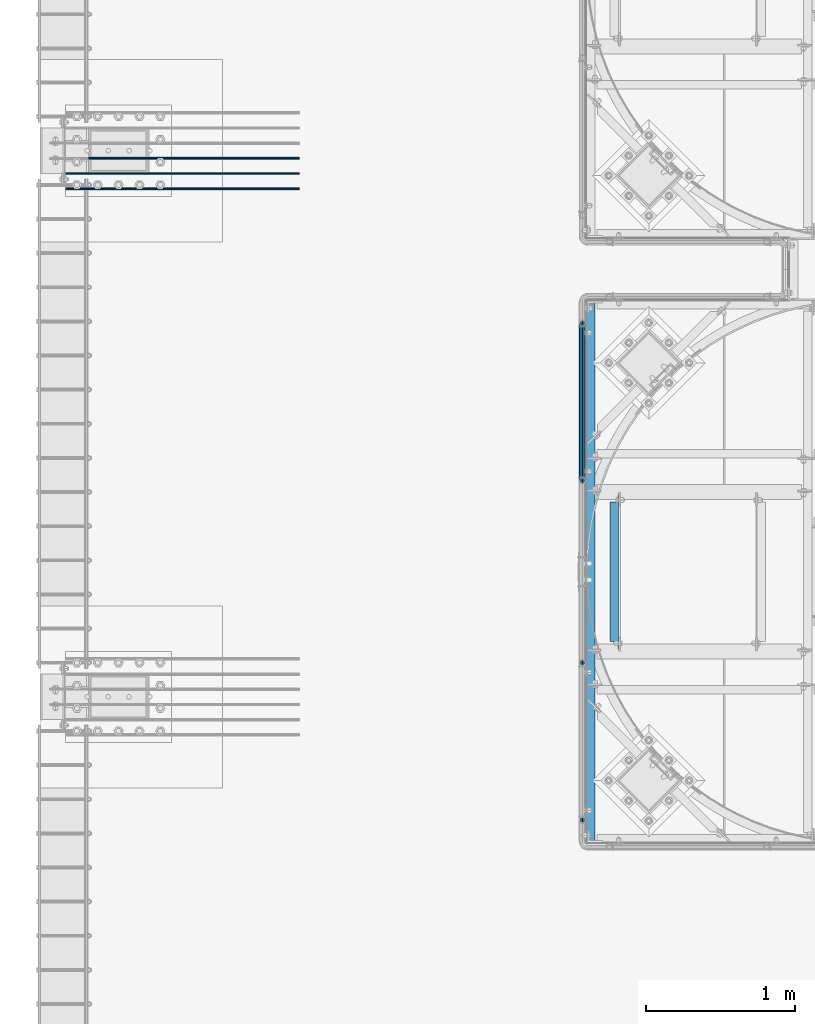
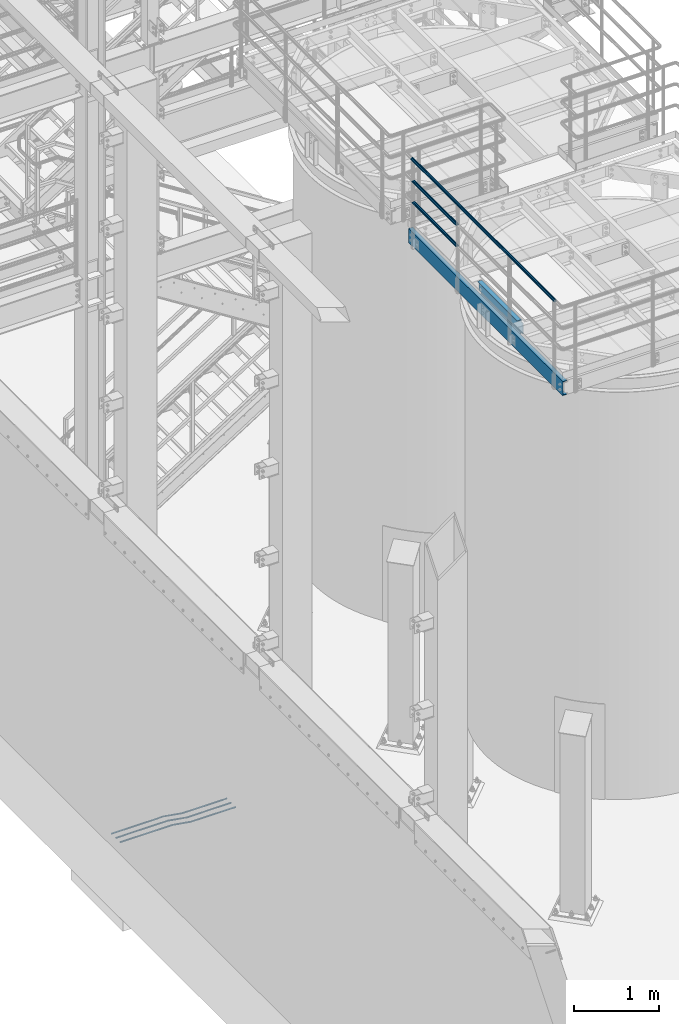
# One storey, part 917 of 1876: 8 beams, 4 elements without a shape of their own.
"""IFC2X3 building model written with IfcOpenShell, lengths in millimetres."""

import ifcopenshell
import ifcopenshell.guid

model = None  # the IFC model being written
_history = None  # IfcOwnerHistory: only IFC2X3 demands one
_inside = {}  # id of a spatial element -> (the spatial element, [elements in it])
_under = {}  # id of a project, library or spatial element -> (it, [spatial elements below it])
_declared = {}  # id of a project -> (the project, [libraries it declares])
_typed = {}  # id of a type object -> (the type object, [elements of that type])
_made_of = {}  # id of a material, layer set ... -> (it, [elements and type objects made of it])


def new_model(schema):
    """Start an empty IFC model of exactly this schema.

    Asked for "IFC4X3", IfcOpenShell would pick the latest addendum, in which some entities
    have other attributes; the version numbers below select the first issue.
    IFC2X3 requires an IfcOwnerHistory on every rooted entity: one is made here for all.
    """
    global model, _history
    if schema == "IFC4X3":
        model = ifcopenshell.file(schema_version=(4, 3, 0, 0))
    else:
        model = ifcopenshell.file(schema=schema)
    _inside.clear()
    _under.clear()
    _declared.clear()
    _typed.clear()
    _made_of.clear()
    _history = None
    if model.schema == "IFC2X3":
        org = make("IfcOrganization", Name="unknown")
        user = make(
            "IfcPersonAndOrganization",
            ThePerson=make("IfcPerson", FamilyName="unknown"),
            TheOrganization=org,
        )
        app = make(
            "IfcApplication",
            ApplicationDeveloper=org,
            Version="unknown",
            ApplicationFullName="unknown",
            ApplicationIdentifier="unknown",
        )
        _history = make(
            "IfcOwnerHistory",
            OwningUser=user,
            OwningApplication=app,
            ChangeAction="ADDED",
            CreationDate=0,
        )
    return model


def make(cls, **values):
    """One entity of the class cls with the attributes given. An attribute that is None is left unset."""
    return model.create_entity(
        cls, **{name: value for name, value in values.items() if value is not None}
    )


def rooted(cls, **values):
    """An entity with a GlobalId (a new one), such as an element, a storey or a relation."""
    return make(cls, GlobalId=ifcopenshell.guid.new(), OwnerHistory=_history, **values)


def si_unit(unit_type, name, prefix=None):
    """IfcSIUnit, for example si_unit("LENGTHUNIT", "METRE", prefix="MILLI")."""
    return make("IfcSIUnit", UnitType=unit_type, Prefix=prefix, Name=name)


def assignment(units):
    """IfcUnitAssignment: the units of a project."""
    return None if units is None else make("IfcUnitAssignment", Units=units)


def point(xyz):
    """IfcCartesianPoint."""
    return None if xyz is None else make("IfcCartesianPoint", Coordinates=xyz)


def direction(xyz):
    """IfcDirection."""
    return None if xyz is None else make("IfcDirection", DirectionRatios=xyz)


def frame(location, z_axis=None, x_axis=None):
    """IfcAxis2Placement3D, a coordinate frame: its origin and axes. An axis left out is left unset."""
    return make(
        "IfcAxis2Placement3D",
        Location=point(location),
        Axis=direction(z_axis),
        RefDirection=direction(x_axis),
    )


def origin_with_axes():
    """The frame at (0, 0, 0) with the z axis (0, 0, 1) and the x axis (1, 0, 0) written out."""
    return frame((0.0, 0.0, 0.0), z_axis=(0.0, 0.0, 1.0), x_axis=(1.0, 0.0, 0.0))


def place(relative_to, where):
    """IfcLocalPlacement: puts the frame where relative to a parent placement (None: the world)."""
    return make(
        "IfcLocalPlacement", PlacementRelTo=relative_to, RelativePlacement=where
    )


def context(
    kind, dimensions, precision=None, world=None, true_north=None, identifier=None
):
    """IfcGeometricRepresentationContext, for example the 3D "Model" context."""
    return make(
        "IfcGeometricRepresentationContext",
        ContextIdentifier=identifier,
        ContextType=kind,
        CoordinateSpaceDimension=dimensions,
        Precision=precision,
        WorldCoordinateSystem=world,
        TrueNorth=true_north,
    )


def subcontext(parent, identifier, kind, view, scale=None):
    """IfcGeometricRepresentationSubContext, for example "Body" below "Model"."""
    return make(
        "IfcGeometricRepresentationSubContext",
        ContextIdentifier=identifier,
        ContextType=kind,
        ParentContext=parent,
        TargetScale=scale,
        TargetView=view,
    )


def project(units=None, contexts=None):
    """IfcProject with its units and contexts."""
    return rooted(
        "IfcProject",
        Name="project",
        RepresentationContexts=contexts,
        UnitsInContext=assignment(units),
    )


def spatial(cls, under=None, at=None, **own):
    """A site, building, storey or space (cls), placed at a placement, below another one or the project."""
    s = rooted(cls, ObjectPlacement=at, **own)
    if under is not None:
        _under.setdefault(under.id(), (under, []))[1].append(s)
    return s


def faces_of(points, faces, orient=None, outer=None):
    """IfcFace entities. A face is a list of loops; a loop is a list of indices into points, from 0.

    orient and outer hold one flag for each loop. By default every Orientation is true, the
    first loop of a face is its IfcFaceOuterBound and the others are IfcFaceBound.
    """
    made = []
    for i, loops in enumerate(faces):
        bounds = []
        for j, loop in enumerate(loops):
            is_outer = j == 0 if outer is None else outer[i][j]
            bounds.append(
                make(
                    "IfcFaceOuterBound" if is_outer else "IfcFaceBound",
                    Bound=make("IfcPolyLoop", Polygon=[points[k] for k in loop]),
                    Orientation=True if orient is None else orient[i][j],
                )
            )
        made.append(make("IfcFace", Bounds=bounds))
    return made


def faceted_brep(points, faces, orient=None, outer=None, voids=None):
    """IfcFacetedBrep: a solid bounded by flat faces; with voids (closed shells), ...WithVoids."""
    shared = [point(p) for p in points]
    hull = make("IfcClosedShell", CfsFaces=faces_of(shared, faces, orient, outer))
    if voids is None:
        return make("IfcFacetedBrep", Outer=hull)
    return make(
        "IfcFacetedBrepWithVoids",
        Outer=hull,
        Voids=[
            make(cls, CfsFaces=faces_of(shared, fs, o, b)) for cls, fs, o, b in voids
        ],
    )


def shape(context_of_items, identifier, shape_type, items):
    """IfcShapeRepresentation: the items that make up one representation, for example the "Body"."""
    return make(
        "IfcShapeRepresentation",
        ContextOfItems=context_of_items,
        RepresentationIdentifier=identifier,
        RepresentationType=shape_type,
        Items=items,
    )


def material(Name=None, Category=None):
    """IfcMaterial."""
    return make("IfcMaterial", Name=Name, Category=Category)


def made_of(thing, what):
    """Note that an element or type object is made of a material, layer set ...; save() writes the relation."""
    if what is not None:
        _made_of.setdefault(what.id(), (what, []))[1].append(thing)
    return thing


def type_object(cls, material=None, **own):
    """A type object (cls), such as IfcWallType, which elements share."""
    return made_of(rooted(cls, **own), material)


def element(
    cls,
    number,
    at=None,
    inside=None,
    cuts=None,
    type_object=None,
    material=None,
    context=None,
    identifier="Body",
    shape_type=None,
    held_by="IfcProductDefinitionShape",
    body=None,
    shapes=None,
    **own,
):
    """One element of the class cls, such as IfcWall. Its Tag is "e" and its number.

    at: its placement. inside: the storey or other place that contains it. cuts: it is an
    opening in that element (IfcRelVoidsElement). A single representation is given by context,
    identifier, shape_type and body (its items); several are given by shapes. held_by: the class
    of the entity that holds the representations. save() writes the other relations.
    """
    e = rooted(cls, Tag="e%d" % number, ObjectPlacement=at, **own)
    if body is not None:
        shapes = [shape(context, identifier, shape_type, body)]
    if shapes is not None:
        e.Representation = make(held_by, Representations=shapes)
    if inside is not None:
        _inside.setdefault(inside.id(), (inside, []))[1].append(e)
    if cuts is not None:
        rooted(
            "IfcRelVoidsElement", RelatingBuildingElement=cuts, RelatedOpeningElement=e
        )
    if type_object is not None:
        _typed.setdefault(type_object.id(), (type_object, []))[1].append(e)
    return made_of(e, material)


def aggregate(whole, parts):
    """IfcRelAggregates: a whole, such as a stair, and the parts it consists of."""
    return rooted("IfcRelAggregates", RelatingObject=whole, RelatedObjects=parts)


def save(model, path):
    """Write the relations noted so far, then the file.

    IfcRelAggregates (storeys below a building ...), IfcRelContainedInSpatialStructure (elements
    in a storey), IfcRelDefinesByType, IfcRelAssociatesMaterial and IfcRelDeclares: one each for
    every whole, place, type object, material and project.
    """
    for whole, parts in _under.values():
        aggregate(whole, parts)
    for where, things in _inside.values():
        rooted(
            "IfcRelContainedInSpatialStructure",
            RelatedElements=things,
            RelatingStructure=where,
        )
    for kind, things in _typed.values():
        rooted("IfcRelDefinesByType", RelatedObjects=things, RelatingType=kind)
    for what, things in _made_of.values():
        rooted("IfcRelAssociatesMaterial", RelatedObjects=things, RelatingMaterial=what)
    for by, libraries in _declared.values():
        rooted("IfcRelDeclares", RelatingContext=by, RelatedDefinitions=libraries)
    model.write(path)


model = new_model("IFC2X3")

# Units and contexts
model_context = context("Model", 3, precision=1e-05, world=origin_with_axes())
body_context = subcontext(model_context, "Body", "Model", "MODEL_VIEW")
ifc_project = project(units=[si_unit("LENGTHUNIT", "METRE", prefix="MILLI"), si_unit("AREAUNIT", "SQUARE_METRE"), si_unit("VOLUMEUNIT", "CUBIC_METRE"), si_unit("MASSUNIT", "GRAM", prefix="KILO"), si_unit("TIMEUNIT", "SECOND"), si_unit("PLANEANGLEUNIT", "RADIAN"), si_unit("SOLIDANGLEUNIT", "STERADIAN"), si_unit("THERMODYNAMICTEMPERATUREUNIT", "DEGREE_CELSIUS"), si_unit("LUMINOUSINTENSITYUNIT", "LUMEN")], contexts=[model_context])

# Site, building, storey
site_placement = place(None, origin_with_axes())
site = spatial("IfcSite", under=ifc_project, at=site_placement, CompositionType="ELEMENT")
building_placement = place(site_placement, origin_with_axes())
building = spatial("IfcBuilding", under=site, at=building_placement, Name="Undefined", CompositionType="ELEMENT")
storey_placement = place(building_placement, origin_with_axes())
storey = spatial("IfcBuildingStorey", under=building, at=storey_placement, Name="Undefined", CompositionType="ELEMENT", Elevation=0.0)

# Assembly, beams
assembly_1_placement = place(storey_placement, origin_with_axes())
assembly_1 = element("IfcElementAssembly", 1, at=assembly_1_placement, inside=storey, Name="HANDRAIL", AssemblyPlace="NOTDEFINED", PredefinedType="RIGID_FRAME")
ifc_material_1 = material()
beam_type_1 = type_object("IfcBeamType", Name="PIPE1-1/4STD", PredefinedType="NOTDEFINED")
beam_1_placement = place(assembly_1_placement, frame((3338.06943150122, -12979.3644042969, 8480.425), z_axis=(0.0, 0.0, 1.0), x_axis=(0.0, 1.0, 0.0)))
beam_1 = element("IfcBeam", 2, at=beam_1_placement, type_object=beam_type_1, material=ifc_material_1, Name="RAIL", ObjectType="PIPE1-1/4STD", context=body_context, shape_type="Brep", body=[
    faceted_brep([(1035.84245243742, -10.5409999999993, 18.2575475625836), (1035.84245243742, -10.5409999999993, 13.3999612267253), (1035.36603877327, -8.76300000000083, 15.1779612267255), (1033.018, 0.0, 17.5259999999998), (1033.018, 0.0, 21.0820000000003), (1035.36603877327, 8.76300000000083, 15.1779612267255), (1035.84245243742, 10.5409999999993, 13.3999612267253), (1035.84245243742, 10.5409999999993, 18.2575475625836), (1054.1, 21.0820000000003, 0.0), (1043.559, 18.2575475625836, 10.5409999999993), (1043.559, 18.2575475625836, -10.5409999999993), (1040.47941366414, 15.1779612267255, 8.76300000000083), (1042.82745243742, 17.5259999999998, 0.0), (1040.47941366414, 15.1779612267255, -8.76300000000083), (1035.84245243742, 10.5409999999993, -13.3999612267253), (1035.84245243742, 10.5409999999993, -18.2575475625836), (1035.36603877327, 8.76300000000083, -15.1779612267255), (1033.018, 0.0, -17.5259999999998), (1033.018, 0.0, -21.0820000000003), (1035.84245243742, -10.5409999999993, -13.3999612267253), (1035.84245243742, -10.5409999999993, -18.2575475625836), (1035.36603877327, -8.76300000000083, -15.1779612267255), (1054.1, -21.0820000000003, 0.0), (1043.559, -18.2575475625836, -10.5409999999993), (1043.559, -18.2575475625836, 10.5409999999993), (1040.47941366414, -15.1779612267255, -8.76300000000083), (1042.82745243742, -17.5259999999998, 0.0), (1040.47941366414, -15.1779612267255, 8.76300000000083), (10.5409999957128, -18.2575475672238, -10.5409999999993), (18.2575475625817, -10.5410000000011, -18.2575475625836), (9.09494701772928e-13, 21.0820000000003, 0.0), (10.5409999957128, 18.2575475579433, -10.5409999999993), (10.5409999999983, 18.2575475625836, 10.5410000000011), (18.2575475625817, 10.5409999999993, 18.2575475625836), (21.0819999999985, 1.81898940354586e-12, 21.0820000000003), (18.2575475625817, 10.5409999999993, -18.2575475625836), (21.0819999999985, 0.0, -21.0819999999985), (21.0819999999985, 0.0, -17.5259999999998), (18.2575475625817, -10.5409999999974, -13.3999612267271), (18.7339612267233, -8.76300000000083, -15.1779612267255), (18.7339612267251, 8.76299999999901, -15.1779612267255), (18.2575475625817, 10.5410000000011, -13.3999612267235), (13.6205863358573, 15.1779612267255, -8.76299999999901), (11.2725475625839, 17.5259999999998, 0.0), (13.6205863358573, 15.1779612267255, 8.76300000000083), (18.2575475625817, 10.5410000000011, 13.3999612267253), (18.7339612267251, 8.76299999999901, 15.1779612267273), (21.0819999999985, 1.81898940354586e-12, 17.5259999999998), (18.7339612267233, -8.76300000000083, 15.1779612267273), (18.2575475625817, -10.5409999999974, 13.3999612267289), (18.2575475625817, -10.5410000000011, 18.2575475625836), (10.5409999999983, -18.2575475625836, 10.5410000000011), (9.09494701772928e-13, -21.0820000000003, 0.0), (13.6205863358537, -15.1779612267255, 8.76300000000083), (11.2725475625793, -17.5259999999998, 0.0), (13.6205863358537, -15.1779612267255, -8.76299999999901)], [[[0, 1, 2, 3, 4]], [[4, 3, 5, 6, 7]], [[8, 9, 10]], [[7, 6, 11, 12, 13, 14, 15, 10, 9]], [[16, 17, 18, 15, 14]], [[19, 20, 18, 17, 21]], [[22, 23, 24]], [[24, 23, 20, 19, 25, 26, 27, 1, 0]], [[28, 29, 20, 23]], [[30, 31, 32]], [[33, 34, 4, 7]], [[32, 33, 7, 9]], [[30, 32, 9, 8]], [[31, 30, 8, 10]], [[35, 31, 10, 15]], [[36, 35, 15, 18]], [[29, 36, 18, 20]], [[37, 36, 29, 38, 39]], [[40, 41, 35, 36, 37]], [[32, 31, 35, 41, 42, 43, 44, 45, 33]], [[33, 45, 46, 47, 34]], [[34, 47, 48, 49, 50]], [[34, 50, 0, 4]], [[50, 51, 24, 0]], [[51, 52, 22, 24]], [[52, 28, 23, 22]], [[51, 28, 52]], [[50, 49, 53, 54, 55, 38, 29, 28, 51]], [[55, 54, 26, 25]], [[21, 39, 38, 55, 25, 19]], [[37, 39, 21, 17]], [[40, 37, 17, 16]], [[42, 41, 40, 16, 14, 13]], [[43, 42, 13, 12]], [[44, 43, 12, 11]], [[5, 46, 45, 44, 11, 6]], [[47, 46, 5, 3]], [[48, 47, 3, 2]], [[53, 49, 48, 2, 1, 27]], [[54, 53, 27, 26]]]),
])
beam_2_placement = place(assembly_1_placement, frame((3338.06943150122, -11925.2644042969, 8785.225), z_axis=(0.0, 0.0, -1.0), x_axis=(0.0, -1.0, 0.0)))
beam_2 = element("IfcBeam", 3, at=beam_2_placement, type_object=beam_type_1, material=ifc_material_1, Name="RAIL", ObjectType="PIPE1-1/4STD", context=body_context, shape_type="Brep", body=[
    faceted_brep([(9.09494701772928e-13, 21.0820000000003, 0.0), (10.5409999957128, 18.2575475579433, -10.5409999999993), (10.5409999999983, 18.2575475625836, 10.5410000000011), (10.5409999999983, -18.2575475625836, 10.5410000000011), (10.5409999957128, -18.2575475672238, -10.5409999999993), (9.09494701772928e-13, -21.0820000000003, 0.0), (18.2575475625817, -10.5410000000011, 18.2575475625836), (18.2575475625817, -10.5409999999974, 13.3999612267289), (13.6205863358537, -15.1779612267255, 8.76300000000083), (11.2725475625793, -17.5259999999998, 0.0), (13.6205863358537, -15.1779612267255, -8.76299999999901), (18.2575475625817, -10.5409999999974, -13.3999612267271), (18.2575475625817, -10.5410000000011, -18.2575475625836), (21.0819999999985, 0.0, -17.5259999999998), (21.0819999999985, 0.0, -21.0819999999985), (18.7339612267233, -8.76300000000083, -15.1779612267255), (18.7339612267251, 8.76299999999901, -15.1779612267255), (18.2575475625817, 10.5410000000011, -13.3999612267235), (18.2575475625817, 10.5409999999993, -18.2575475625836), (13.6205863358573, 15.1779612267255, -8.76299999999901), (11.2725475625839, 17.5259999999998, 0.0), (13.6205863358573, 15.1779612267255, 8.76300000000083), (18.2575475625817, 10.5410000000011, 13.3999612267253), (18.2575475625817, 10.5409999999993, 18.2575475625836), (18.7339612267251, 8.76299999999901, 15.1779612267273), (21.0819999999985, 1.81898940354586e-12, 17.5259999999998), (21.0819999999985, 1.81898940354586e-12, 21.0820000000003), (18.7339612267233, -8.76300000000083, 15.1779612267273), (1054.1, 21.0820000000003, 0.0), (1043.559, 18.2575475625836, -10.5409999999993), (1035.84245243742, 10.5409999999993, -18.2575475625836), (1054.1, -21.0820000000003, 0.0), (1043.559, -18.2575475625836, -10.5409999999993), (1043.559, -18.2575475625836, 10.5409999999993), (1035.84245243742, -10.5409999999993, 18.2575475625836), (1035.84245243742, -10.5409999999993, -18.2575475625836), (1033.018, 0.0, -21.0820000000003), (1035.36603877327, 8.76300000000083, -15.1779612267255), (1033.018, 0.0, -17.5259999999998), (1035.84245243742, 10.5409999999993, -13.3999612267253), (1035.84245243742, -10.5409999999993, -13.3999612267253), (1035.36603877327, -8.76300000000083, -15.1779612267255), (1040.47941366414, -15.1779612267255, -8.76300000000083), (1042.82745243742, -17.5259999999998, 0.0), (1040.47941366414, -15.1779612267255, 8.76300000000083), (1035.84245243742, -10.5409999999993, 13.3999612267253), (1035.36603877327, -8.76300000000083, 15.1779612267255), (1033.018, 0.0, 17.5259999999998), (1033.018, 0.0, 21.0820000000003), (1035.84245243742, 10.5409999999993, 18.2575475625836), (1043.559, 18.2575475625836, 10.5409999999993), (1035.84245243742, 10.5409999999993, 13.3999612267253), (1040.47941366414, 15.1779612267255, 8.76300000000083), (1042.82745243742, 17.5259999999998, 0.0), (1040.47941366414, 15.1779612267255, -8.76300000000083), (1035.36603877327, 8.76300000000083, 15.1779612267255)], [[[0, 1, 2]], [[3, 4, 5]], [[6, 7, 8, 9, 10, 11, 12, 4, 3]], [[13, 14, 12, 11, 15]], [[16, 17, 18, 14, 13]], [[2, 1, 18, 17, 19, 20, 21, 22, 23]], [[23, 22, 24, 25, 26]], [[26, 25, 27, 7, 6]], [[1, 0, 28, 29]], [[18, 1, 29, 30]], [[31, 32, 33]], [[6, 3, 33, 34]], [[3, 5, 31, 33]], [[5, 4, 32, 31]], [[4, 12, 35, 32]], [[12, 14, 36, 35]], [[14, 18, 30, 36]], [[37, 38, 36, 30, 39]], [[40, 35, 36, 38, 41]], [[33, 32, 35, 40, 42, 43, 44, 45, 34]], [[34, 45, 46, 47, 48]], [[26, 6, 34, 48]], [[2, 23, 49, 50]], [[23, 26, 48, 49]], [[0, 2, 50, 28]], [[28, 50, 29]], [[49, 51, 52, 53, 54, 39, 30, 29, 50]], [[48, 47, 55, 51, 49]], [[25, 24, 55, 47]], [[55, 24, 22, 21, 52, 51]], [[21, 20, 53, 52]], [[20, 19, 54, 53]], [[19, 17, 16, 37, 39, 54]], [[16, 13, 38, 37]], [[13, 15, 41, 38]], [[41, 15, 11, 10, 42, 40]], [[10, 9, 43, 42]], [[9, 8, 44, 43]], [[8, 7, 27, 46, 45, 44]], [[27, 25, 47, 46]]]),
])
beam_3_placement = place(assembly_1_placement, frame((3338.06943150122, -11904.1824042969, 9090.025), z_axis=(0.0, 0.0, -1.0), x_axis=(0.0, -1.0, 0.0)))
beam_3 = element("IfcBeam", 4, at=beam_3_placement, type_object=beam_type_1, material=ifc_material_1, Name="HANDRAIL", ObjectType="PIPE1-1/4STD", context=body_context, shape_type="Brep", body=[
    faceted_brep([(0.0, -17.5259999999998, 0.0), (0.0, -15.1779612267264, 8.76300000000083), (3369.564, -15.177961226726, 8.76300000000083), (3369.564, -17.5259999999998, 0.0), (0.0, -8.76299999999992, 15.1779612267255), (3369.564, -8.76299999999992, 15.1779612267255), (0.0, 0.0, 17.5259999999998), (3369.564, 0.0, 17.5259999999998), (0.0, 8.76299999999992, 15.1779612267255), (3369.564, 8.76299999999992, 15.1779612267255), (0.0, 15.1779612267264, 8.76300000000083), (3369.564, 15.177961226726, 8.76300000000083), (0.0, 17.5259999999998, 0.0), (3369.564, 17.5259999999998, 0.0), (0.0, 15.1779612267264, -8.76300000000083), (3369.564, 15.177961226726, -8.76300000000083), (0.0, 8.76299999999992, -15.1779612267255), (3369.564, 8.76299999999992, -15.1779612267255), (0.0, 0.0, -17.5259999999998), (3369.564, 0.0, -17.5259999999998), (0.0, -8.76299999999992, -15.1779612267255), (3369.564, -8.76299999999992, -15.1779612267255), (0.0, -15.1779612267264, -8.76300000000083), (3369.564, -15.177961226726, -8.76300000000083), (9.09494701772928e-13, -21.0820000000003, 0.0), (0.0, -18.2575475625836, -10.5409999999993), (3369.564, -18.2575475625836, -10.5409999999993), (3369.564, -21.0819999999999, 0.0), (0.0, -10.5410000000002, -18.2575475625836), (3369.564, -10.5410000000002, -18.2575475625836), (-4.28826751885936e-09, 0.0, -21.0820000000003), (3369.564, 0.0, -21.0820000000003), (0.0, 10.5410000000002, -18.2575475625836), (3369.564, 10.5410000000002, -18.2575475625836), (0.0, 18.2575475625836, -10.5409999999993), (3369.564, 18.2575475625836, -10.5409999999993), (9.09494701772928e-13, 21.0820000000003, 0.0), (3369.564, 21.0819999999999, 0.0), (0.0, 18.2575475625836, 10.5409999999993), (3369.564, 18.2575475625836, 10.5409999999993), (0.0, 10.5410000000002, 18.2575475625836), (3369.564, 10.5410000000002, 18.2575475625836), (0.0, 0.0, 21.0820000000003), (3369.564, 0.0, 21.0820000000003), (0.0, -10.5410000000002, 18.2575475625836), (3369.564, -10.5410000000002, 18.2575475625836), (0.0, -18.2575475625836, 10.5409999999993), (3369.564, -18.2575475625836, 10.5409999999993)], [[[0, 1, 2, 3]], [[1, 4, 5, 2]], [[4, 6, 7, 5]], [[6, 8, 9, 7]], [[8, 10, 11, 9]], [[10, 12, 13, 11]], [[12, 14, 15, 13]], [[14, 16, 17, 15]], [[16, 18, 19, 17]], [[18, 20, 21, 19]], [[20, 22, 23, 21]], [[22, 0, 3, 23]], [[24, 25, 26, 27]], [[25, 28, 29, 26]], [[28, 30, 31, 29]], [[30, 32, 33, 31]], [[32, 34, 35, 33]], [[34, 36, 37, 35]], [[36, 38, 39, 37]], [[38, 40, 41, 39]], [[40, 42, 43, 41]], [[42, 44, 45, 43]], [[44, 46, 47, 45]], [[46, 24, 27, 47]], [[29, 31, 33, 35, 37, 39, 41, 43, 45, 47, 27, 26], [5, 7, 9, 11, 13, 15, 17, 19, 21, 23, 3, 2]], [[46, 44, 42, 40, 38, 36, 34, 32, 30, 28, 25, 24], [22, 20, 18, 16, 14, 12, 10, 8, 6, 4, 1, 0]]]),
])
aggregate(assembly_1, [beam_1, beam_2, beam_3])

# Assembly, beam
assembly_2_placement = place(storey_placement, origin_with_axes())
assembly_2 = element("IfcElementAssembly", 5, at=assembly_2_placement, inside=storey, Name="BEAM", AssemblyPlace="NOTDEFINED", PredefinedType="RIGID_FRAME")
ifc_material_2 = material(Name="STEEL/A36")
beam_type_2 = type_object("IfcBeamType", Name="C8X11.5", PredefinedType="NOTDEFINED")
beam_4_placement = place(assembly_2_placement, frame((3552.82643150122, -14122.3644042969, 7896.225), z_axis=(0.0, 0.0, -1.0), x_axis=(0.0, 1.0, 0.0)))
beam_4 = element("IfcBeam", 6, at=beam_4_placement, type_object=beam_type_2, material=ifc_material_2, Name="BEAM", ObjectType="C8X11.5", context=body_context, shape_type="Brep", body=[
    faceted_brep([(15.875, 22.2250000000004, -76.1999999999989), (15.875, 28.5749999999998, -76.1999999999989), (53.9750001907378, 28.5749999999998, -76.1999999999989), (53.9750001907378, 22.2250000000004, -76.1999999999989), (58.8350797087842, 28.5749999999998, -77.1667299225865), (58.8350797087842, 22.2250000000004, -77.1667299225865), (62.9552561769378, 28.5749999999998, -79.9197438230649), (62.9552561769378, 22.2250000000004, -79.9197438230649), (65.7082700774154, 28.5749999999998, -84.0399202912186), (65.7082700774154, 22.2250000000004, -84.0399202912186), (66.6750000000029, 19.0576241940935, -88.899999809264), (66.6750000000029, 28.5749999999998, -88.899999809264), (66.6750000000029, 28.5749999999998, -101.6), (66.6750000000029, -28.5749999999998, -101.6), (66.6750000000029, -28.5749999999998, -96.8355949999996), (66.5700369653623, 22.2250000000004, -88.3723149999996), (1000.125, -28.5749999999998, -96.8355949999996), (1000.125, -28.5749999999998, -101.6), (1000.125, 28.5749999999998, -101.6), (1000.125, 28.5749999999998, -88.899999809264), (1000.125, 19.0576241940935, -88.899999809264), (1000.125, -28.5749999999998, 96.8355949999996), (1000.125, -28.5749999999998, 101.6), (66.6750000000029, -28.5749999999998, 101.6), (66.6750000000029, -28.5749999999998, 96.8355949999996), (1000.125, 19.0576241940826, 88.8999998092659), (1000.125, 28.5749999999998, 88.8999998092659), (1000.125, 28.5749999999998, 101.6), (66.6750000000029, 28.5749999999998, 101.6), (53.9750001907378, 22.2250000000004, 76.2000000000007), (53.9750001907378, 28.5749999999998, 76.2000000000007), (15.875, 28.5749999999998, 76.2000000000007), (15.875, 22.2250000000004, 76.2000000000007), (58.8350797087842, 22.2250000000004, 77.1667299225883), (58.8350797087842, 28.5749999999998, 77.1667299225883), (62.9552561769378, 22.2250000000004, 79.9197438230667), (62.9552561769378, 28.5749999999998, 79.9197438230667), (65.7082700774154, 22.2250000000004, 84.0399202912204), (65.7082700774154, 28.5749999999998, 84.0399202912204), (66.6750000000029, 19.0576241940826, 88.8999998092659), (66.6750000000029, 28.5749999999998, 88.8999998092659), (66.5700369653623, 22.2250000000004, 88.3723149999996), (1000.22996303464, 22.2250000000004, 88.3723149999996), (1001.09172992259, 22.2250000000004, 84.0399202912204), (1001.09172992259, 28.5749999999998, 84.0399202912204), (1003.84474382307, 22.2250000000004, 79.9197438230667), (1003.84474382307, 28.5749999999998, 79.9197438230667), (1007.96492029122, 22.2250000000004, 77.1667299225883), (1007.96492029122, 28.5749999999998, 77.1667299225883), (1012.82499980927, 22.2250000000004, 76.2000000000007), (1012.82499980927, 28.5749999999998, 76.2000000000007), (1050.925, 22.2250000000004, 76.2000000000007), (1050.925, 28.5749999999998, 76.2000000000007), (1050.925, 22.2250000000004, -76.1999999999989), (1050.925, 28.5749999999998, -76.1999999999989), (1012.82499980927, 22.2250000000004, -76.1999999999989), (1012.82499980927, 28.5749999999998, -76.1999999999989), (1007.96492029122, 22.2250000000004, -77.1667299225865), (1007.96492029122, 28.5749999999998, -77.1667299225865), (1003.84474382307, 22.2250000000004, -79.9197438230649), (1003.84474382307, 28.5749999999998, -79.9197438230649), (1001.09172992259, 22.2250000000004, -84.0399202912186), (1001.09172992259, 28.5749999999998, -84.0399202912186), (1000.22996303464, 22.2250000000004, -88.3723149999996)], [[[0, 1, 2, 3]], [[3, 2, 4, 5]], [[5, 4, 6, 7]], [[7, 6, 8, 9]], [[10, 11, 12, 13, 14]], [[15, 9, 8, 11, 10]], [[16, 17, 18, 19, 20]], [[21, 22, 23, 24]], [[22, 21, 25, 26, 27]], [[22, 27, 28, 23]], [[29, 30, 31, 32]], [[33, 34, 30, 29]], [[35, 36, 34, 33]], [[37, 38, 36, 35]], [[39, 40, 38, 37, 41]], [[23, 28, 40, 39, 24]], [[41, 42, 25, 21, 24, 39]], [[43, 44, 26, 25, 42]], [[45, 46, 44, 43]], [[47, 48, 46, 45]], [[49, 50, 48, 47]], [[51, 52, 50, 49]], [[52, 51, 53, 54]], [[53, 55, 56, 54]], [[57, 58, 56, 55]], [[59, 60, 58, 57]], [[61, 62, 60, 59]], [[63, 20, 19, 62, 61]], [[14, 16, 20, 63, 15, 10]], [[17, 16, 14, 13]], [[18, 17, 13, 12]], [[6, 4, 2, 1, 31, 30, 34, 36, 38, 40, 28, 27, 26, 44, 46, 48, 50, 52, 54, 56, 58, 60, 62, 19, 18, 12, 11, 8]], [[32, 31, 1, 0]], [[63, 61, 59, 57, 55, 53, 51, 49, 47, 45, 43, 42, 41, 37, 35, 33, 29, 32, 0, 3, 5, 7, 9, 15]]]),
])
aggregate(assembly_2, [beam_4])

assembly_3_placement = place(storey_placement, origin_with_axes())
assembly_3 = element("IfcElementAssembly", 7, at=assembly_3_placement, inside=storey, Name="BEAM", AssemblyPlace="NOTDEFINED", PredefinedType="RIGID_FRAME")
beam_5_placement = place(assembly_3_placement, frame((3394.07643150122, -15405.0644042969, 7896.225), z_axis=(0.0, 0.0, 1.0), x_axis=(0.0, 1.0, 0.0)))
beam_5 = element("IfcBeam", 8, at=beam_5_placement, type_object=beam_type_2, material=ifc_material_2, Name="BEAM", ObjectType="C8X11.5", context=body_context, shape_type="Brep", body=[
    faceted_brep([(0.0, 28.5749999999998, -101.6), (0.0, 28.5749999999998, 101.6), (3632.1999511731, 28.5749999999998, 101.6), (3632.1999511731, 28.5749999999998, -101.6), (0.0, -28.5749999999998, 101.6), (3632.1999511731, -28.5749999999998, 101.6), (0.0, -28.5749999999998, 96.8355950000005), (3632.1999511731, -28.5749999999998, 96.8355949999996), (0.0, 22.2250000000004, 88.3723150000005), (3632.1999511731, 22.2250000000004, 88.3723149999996), (0.0, 22.2250000000004, -88.3723150000005), (3632.1999511731, 22.2250000000004, -88.3723149999996), (0.0, -28.5749999999998, -96.8355950000005), (3632.1999511731, -28.5749999999998, -96.8355949999996), (0.0, -28.5749999999998, -101.6), (3632.1999511731, -28.5749999999998, -101.6)], [[[0, 1, 2, 3]], [[1, 4, 5, 2]], [[4, 6, 7, 5]], [[6, 8, 9, 7]], [[8, 10, 11, 9]], [[10, 12, 13, 11]], [[12, 14, 15, 13]], [[14, 0, 3, 15]], [[5, 7, 9, 11, 13, 15, 3, 2]], [[14, 12, 10, 8, 6, 4, 1, 0]]]),
])
aggregate(assembly_3, [beam_5])

# Assembly, beams
assembly_4_placement = place(storey_placement, origin_with_axes())
assembly_4 = element("IfcElementAssembly", 9, at=assembly_4_placement, inside=storey, Name="PLATE", AssemblyPlace="NOTDEFINED", PredefinedType="RIGID_FRAME")
ifc_material_3 = material(Name="STEEL/A706-GR.60")
beam_type_3 = type_object("IfcBeamType", Name="5 REBAR", PredefinedType="NOTDEFINED")
beam_6_placement = place(assembly_4_placement, frame((-123.825012207031, -10921.999983724, -58.7375000000029), z_axis=(0.0, 1.0, 0.0), x_axis=(1.0, 0.0, 0.0)))
beam_6 = element("IfcBeam", 10, at=beam_6_placement, type_object=beam_type_3, material=ifc_material_3, Name="REBAR", ObjectType="5 REBAR", context=body_context, shape_type="Brep", body=[
    faceted_brep([(0.0, -7.9375, 0.0), (0.0, -5.61266007566822, -5.61266007566883), (710.034986674476, -5.61266007566822, -5.61266007566883), (710.034986674476, -7.9375, 0.0), (0.0, 0.0, -7.9375), (710.034986674476, 0.0, -7.9375), (0.0, 5.61266007566822, -5.61266007566883), (710.034986674476, 5.61266007566822, -5.61266007566883), (0.0, 7.9375, 0.0), (710.034986674476, 7.9375, 0.0), (0.0, 5.61266007566822, 5.61266007566883), (710.034986674476, 5.61266007566822, 5.61266007566883), (0.0, 0.0, 7.9375), (710.034986674476, 0.0, 7.9375), (0.0, -5.61266007566822, 5.61266007566883), (710.034986674476, -5.61266007566822, 5.61266007566883), (711.670256270764, -5.61266007566822, -5.61266007566883), (711.865037739587, -7.9375, 0.0), (711.200012207031, 0.0, -7.9375), (710.729768143299, 5.61266007566822, -5.61266007566883), (710.534986674476, 7.9375, 0.0), (710.729768143299, 5.61266007566822, 5.61266007566883), (711.200012207031, 0.0, 7.9375), (711.670256270764, -5.61266007566822, 5.61266007566883), (713.282728188834, -5.34055537895146, -5.61266007566883), (713.669575632193, -7.63298416286913, 0.0), (712.34879584451, 0.193857281957023, -7.9375), (711.414863500185, 5.72826994286551, -5.61266007566883), (711.028016056827, 8.02069872678318, 0.0), (711.414863500185, 5.72826994286551, 5.61266007566883), (712.34879584451, 0.193857281957023, 7.9375), (713.282728188834, -5.34055537895146, 5.61266007566883), (964.985099878721, 37.1342292941951, -5.61266007566883), (965.371947322079, 34.8418005102774, 0.0), (964.051167534397, 42.6686419551035, -7.9375), (963.117235190072, 48.203054616012, -5.61266007566883), (962.730387746714, 50.4954833999297, 0.0), (963.117235190072, 48.203054616012, 5.61266007566883), (964.051167534397, 42.6686419551035, 7.9375), (964.985099878721, 37.1342292941951, 5.61266007566883), (965.670195235607, 37.2498391613923, -5.61266007566883), (965.864976704431, 34.9249992370606, 0.0), (965.199951171875, 42.8624992370605, -7.9375), (964.729707108143, 48.4751593127287, -5.61266007566883), (964.534925639319, 50.7999992370605, 0.0), (964.729707108143, 48.4751593127287, 5.61266007566883), (965.199951171875, 42.8624992370605, 7.9375), (965.670195235607, 37.2498391613923, 5.61266007566883), (966.36497670443, 37.2498391613923, -5.61266007566883), (966.36497670443, 34.9249992370605, 0.0), (966.36497670443, 42.8624992370605, -7.9375), (966.36497670443, 48.4751593127288, -5.61266007566883), (966.36497670443, 50.7999992370605, 0.0), (966.36497670443, 48.4751593127288, 5.61266007566883), (966.36497670443, 42.8624992370605, 7.9375), (966.36497670443, 37.2498391613923, 5.61266007566883), (1566.86254882812, 37.2498391613923, -5.61266007566883), (1566.86254882812, 34.9249992370605, 0.0), (1566.86254882812, 42.8624992370605, -7.9375), (1566.86254882812, 48.4751593127288, -5.61266007566883), (1566.86254882812, 50.7999992370605, 0.0), (1566.86254882812, 48.4751593127288, 5.61266007566883), (1566.86254882812, 42.8624992370605, 7.9375), (1566.86254882812, 37.2498391613923, 5.61266007566883)], [[[0, 1, 2, 3]], [[1, 4, 5, 2]], [[4, 6, 7, 5]], [[6, 8, 9, 7]], [[8, 10, 11, 9]], [[10, 12, 13, 11]], [[12, 14, 15, 13]], [[14, 0, 3, 15]], [[14, 12, 10, 8, 6, 4, 1, 0]], [[3, 2, 16, 17]], [[2, 5, 18, 16]], [[5, 7, 19, 18]], [[7, 9, 20, 19]], [[9, 11, 21, 20]], [[11, 13, 22, 21]], [[13, 15, 23, 22]], [[15, 3, 17, 23]], [[17, 16, 24, 25]], [[16, 18, 26, 24]], [[18, 19, 27, 26]], [[19, 20, 28, 27]], [[20, 21, 29, 28]], [[21, 22, 30, 29]], [[22, 23, 31, 30]], [[23, 17, 25, 31]], [[25, 24, 32, 33]], [[24, 26, 34, 32]], [[26, 27, 35, 34]], [[27, 28, 36, 35]], [[28, 29, 37, 36]], [[29, 30, 38, 37]], [[30, 31, 39, 38]], [[31, 25, 33, 39]], [[33, 32, 40, 41]], [[32, 34, 42, 40]], [[34, 35, 43, 42]], [[35, 36, 44, 43]], [[36, 37, 45, 44]], [[37, 38, 46, 45]], [[38, 39, 47, 46]], [[39, 33, 41, 47]], [[41, 40, 48, 49]], [[40, 42, 50, 48]], [[42, 43, 51, 50]], [[43, 44, 52, 51]], [[44, 45, 53, 52]], [[45, 46, 54, 53]], [[46, 47, 55, 54]], [[47, 41, 49, 55]], [[49, 48, 56, 57]], [[48, 50, 58, 56]], [[50, 51, 59, 58]], [[51, 52, 60, 59]], [[52, 53, 61, 60]], [[53, 54, 62, 61]], [[54, 55, 63, 62]], [[55, 49, 57, 63]], [[58, 59, 60, 61, 62, 63, 57, 56]]]),
])
beam_7_placement = place(assembly_4_placement, frame((-123.825012207031, -10820.399983724, -58.7375000000029), z_axis=(0.0, 1.0, 0.0), x_axis=(1.0, 0.0, 0.0)))
beam_7 = element("IfcBeam", 11, at=beam_7_placement, type_object=beam_type_3, material=ifc_material_3, Name="REBAR", ObjectType="5 REBAR", context=body_context, shape_type="Brep", body=[
    faceted_brep([(0.0, -7.9375, 0.0), (0.0, -5.61266007566822, -5.61266007566883), (710.034986674476, -5.61266007566822, -5.61266007566883), (710.034986674476, -7.9375, 0.0), (0.0, 0.0, -7.9375), (710.034986674476, 0.0, -7.9375), (0.0, 5.61266007566822, -5.61266007566883), (710.034986674476, 5.61266007566822, -5.61266007566883), (0.0, 7.9375, 0.0), (710.034986674476, 7.9375, 0.0), (0.0, 5.61266007566822, 5.61266007566883), (710.034986674476, 5.61266007566822, 5.61266007566883), (0.0, 0.0, 7.9375), (710.034986674476, 0.0, 7.9375), (0.0, -5.61266007566822, 5.61266007566883), (710.034986674476, -5.61266007566822, 5.61266007566883), (711.670256270764, -5.61266007566822, -5.61266007566883), (711.865037739587, -7.9375, 0.0), (711.200012207031, 0.0, -7.9375), (710.729768143299, 5.61266007566822, -5.61266007566883), (710.534986674476, 7.9375, 0.0), (710.729768143299, 5.61266007566822, 5.61266007566883), (711.200012207031, 0.0, 7.9375), (711.670256270764, -5.61266007566822, 5.61266007566883), (713.282728188834, -5.34055537895146, -5.61266007566883), (713.669575632193, -7.63298416286913, 0.0), (712.34879584451, 0.193857281957023, -7.9375), (711.414863500185, 5.72826994286551, -5.61266007566883), (711.028016056827, 8.02069872678318, 0.0), (711.414863500185, 5.72826994286551, 5.61266007566883), (712.34879584451, 0.193857281957023, 7.9375), (713.282728188834, -5.34055537895146, 5.61266007566883), (964.985099878721, 37.1342292941951, -5.61266007566883), (965.371947322079, 34.8418005102774, 0.0), (964.051167534397, 42.6686419551035, -7.9375), (963.117235190072, 48.203054616012, -5.61266007566883), (962.730387746714, 50.4954833999297, 0.0), (963.117235190072, 48.203054616012, 5.61266007566883), (964.051167534397, 42.6686419551035, 7.9375), (964.985099878721, 37.1342292941951, 5.61266007566883), (965.670195235607, 37.2498391613923, -5.61266007566883), (965.864976704431, 34.9249992370606, 0.0), (965.199951171875, 42.8624992370605, -7.9375), (964.729707108143, 48.4751593127287, -5.61266007566883), (964.534925639319, 50.7999992370605, 0.0), (964.729707108143, 48.4751593127287, 5.61266007566883), (965.199951171875, 42.8624992370605, 7.9375), (965.670195235607, 37.2498391613923, 5.61266007566883), (966.36497670443, 37.2498391613923, -5.61266007566883), (966.36497670443, 34.9249992370605, 0.0), (966.36497670443, 42.8624992370605, -7.9375), (966.36497670443, 48.4751593127288, -5.61266007566883), (966.36497670443, 50.7999992370605, 0.0), (966.36497670443, 48.4751593127288, 5.61266007566883), (966.36497670443, 42.8624992370605, 7.9375), (966.36497670443, 37.2498391613923, 5.61266007566883), (1566.86254882812, 37.2498391613923, -5.61266007566883), (1566.86254882812, 34.9249992370605, 0.0), (1566.86254882812, 42.8624992370605, -7.9375), (1566.86254882812, 48.4751593127288, -5.61266007566883), (1566.86254882812, 50.7999992370605, 0.0), (1566.86254882812, 48.4751593127288, 5.61266007566883), (1566.86254882812, 42.8624992370605, 7.9375), (1566.86254882812, 37.2498391613923, 5.61266007566883)], [[[0, 1, 2, 3]], [[1, 4, 5, 2]], [[4, 6, 7, 5]], [[6, 8, 9, 7]], [[8, 10, 11, 9]], [[10, 12, 13, 11]], [[12, 14, 15, 13]], [[14, 0, 3, 15]], [[14, 12, 10, 8, 6, 4, 1, 0]], [[3, 2, 16, 17]], [[2, 5, 18, 16]], [[5, 7, 19, 18]], [[7, 9, 20, 19]], [[9, 11, 21, 20]], [[11, 13, 22, 21]], [[13, 15, 23, 22]], [[15, 3, 17, 23]], [[17, 16, 24, 25]], [[16, 18, 26, 24]], [[18, 19, 27, 26]], [[19, 20, 28, 27]], [[20, 21, 29, 28]], [[21, 22, 30, 29]], [[22, 23, 31, 30]], [[23, 17, 25, 31]], [[25, 24, 32, 33]], [[24, 26, 34, 32]], [[26, 27, 35, 34]], [[27, 28, 36, 35]], [[28, 29, 37, 36]], [[29, 30, 38, 37]], [[30, 31, 39, 38]], [[31, 25, 33, 39]], [[33, 32, 40, 41]], [[32, 34, 42, 40]], [[34, 35, 43, 42]], [[35, 36, 44, 43]], [[36, 37, 45, 44]], [[37, 38, 46, 45]], [[38, 39, 47, 46]], [[39, 33, 41, 47]], [[41, 40, 48, 49]], [[40, 42, 50, 48]], [[42, 43, 51, 50]], [[43, 44, 52, 51]], [[44, 45, 53, 52]], [[45, 46, 54, 53]], [[46, 47, 55, 54]], [[47, 41, 49, 55]], [[49, 48, 56, 57]], [[48, 50, 58, 56]], [[50, 51, 59, 58]], [[51, 52, 60, 59]], [[52, 53, 61, 60]], [[53, 54, 62, 61]], [[54, 55, 63, 62]], [[55, 49, 57, 63]], [[58, 59, 60, 61, 62, 63, 57, 56]]]),
])
beam_8_placement = place(assembly_4_placement, frame((-123.825012207031, -11023.599983724, -58.7375000000029), z_axis=(0.0, 1.0, 0.0), x_axis=(1.0, 0.0, 0.0)))
beam_8 = element("IfcBeam", 12, at=beam_8_placement, type_object=beam_type_3, material=ifc_material_3, Name="REBAR", ObjectType="5 REBAR", context=body_context, shape_type="Brep", body=[
    faceted_brep([(0.0, -7.9375, 0.0), (0.0, -5.61266007566822, -5.61266007566883), (710.034986674476, -5.61266007566822, -5.61266007566883), (710.034986674476, -7.9375, 0.0), (0.0, 0.0, -7.9375), (710.034986674476, 0.0, -7.9375), (0.0, 5.61266007566822, -5.61266007566883), (710.034986674476, 5.61266007566822, -5.61266007566883), (0.0, 7.9375, 0.0), (710.034986674476, 7.9375, 0.0), (0.0, 5.61266007566822, 5.61266007566883), (710.034986674476, 5.61266007566822, 5.61266007566883), (0.0, 0.0, 7.9375), (710.034986674476, 0.0, 7.9375), (0.0, -5.61266007566822, 5.61266007566883), (710.034986674476, -5.61266007566822, 5.61266007566883), (711.670256270764, -5.61266007566822, -5.61266007566883), (711.865037739587, -7.9375, 0.0), (711.200012207031, 0.0, -7.9375), (710.729768143299, 5.61266007566822, -5.61266007566883), (710.534986674476, 7.9375, 0.0), (710.729768143299, 5.61266007566822, 5.61266007566883), (711.200012207031, 0.0, 7.9375), (711.670256270764, -5.61266007566822, 5.61266007566883), (713.282728188834, -5.34055537895146, -5.61266007566883), (713.669575632193, -7.63298416286913, 0.0), (712.34879584451, 0.193857281957023, -7.9375), (711.414863500185, 5.72826994286551, -5.61266007566883), (711.028016056827, 8.02069872678318, 0.0), (711.414863500185, 5.72826994286551, 5.61266007566883), (712.34879584451, 0.193857281957023, 7.9375), (713.282728188834, -5.34055537895146, 5.61266007566883), (964.985099878721, 37.1342292941951, -5.61266007566883), (965.371947322079, 34.8418005102774, 0.0), (964.051167534397, 42.6686419551035, -7.9375), (963.117235190072, 48.203054616012, -5.61266007566883), (962.730387746714, 50.4954833999297, 0.0), (963.117235190072, 48.203054616012, 5.61266007566883), (964.051167534397, 42.6686419551035, 7.9375), (964.985099878721, 37.1342292941951, 5.61266007566883), (965.670195235607, 37.2498391613923, -5.61266007566883), (965.864976704431, 34.9249992370606, 0.0), (965.199951171875, 42.8624992370605, -7.9375), (964.729707108143, 48.4751593127287, -5.61266007566883), (964.534925639319, 50.7999992370605, 0.0), (964.729707108143, 48.4751593127287, 5.61266007566883), (965.199951171875, 42.8624992370605, 7.9375), (965.670195235607, 37.2498391613923, 5.61266007566883), (966.36497670443, 37.2498391613923, -5.61266007566883), (966.36497670443, 34.9249992370605, 0.0), (966.36497670443, 42.8624992370605, -7.9375), (966.36497670443, 48.4751593127288, -5.61266007566883), (966.36497670443, 50.7999992370605, 0.0), (966.36497670443, 48.4751593127288, 5.61266007566883), (966.36497670443, 42.8624992370605, 7.9375), (966.36497670443, 37.2498391613923, 5.61266007566883), (1566.86254882812, 37.2498391613923, -5.61266007566883), (1566.86254882812, 34.9249992370605, 0.0), (1566.86254882812, 42.8624992370605, -7.9375), (1566.86254882812, 48.4751593127288, -5.61266007566883), (1566.86254882812, 50.7999992370605, 0.0), (1566.86254882812, 48.4751593127288, 5.61266007566883), (1566.86254882812, 42.8624992370605, 7.9375), (1566.86254882812, 37.2498391613923, 5.61266007566883)], [[[0, 1, 2, 3]], [[1, 4, 5, 2]], [[4, 6, 7, 5]], [[6, 8, 9, 7]], [[8, 10, 11, 9]], [[10, 12, 13, 11]], [[12, 14, 15, 13]], [[14, 0, 3, 15]], [[14, 12, 10, 8, 6, 4, 1, 0]], [[3, 2, 16, 17]], [[2, 5, 18, 16]], [[5, 7, 19, 18]], [[7, 9, 20, 19]], [[9, 11, 21, 20]], [[11, 13, 22, 21]], [[13, 15, 23, 22]], [[15, 3, 17, 23]], [[17, 16, 24, 25]], [[16, 18, 26, 24]], [[18, 19, 27, 26]], [[19, 20, 28, 27]], [[20, 21, 29, 28]], [[21, 22, 30, 29]], [[22, 23, 31, 30]], [[23, 17, 25, 31]], [[25, 24, 32, 33]], [[24, 26, 34, 32]], [[26, 27, 35, 34]], [[27, 28, 36, 35]], [[28, 29, 37, 36]], [[29, 30, 38, 37]], [[30, 31, 39, 38]], [[31, 25, 33, 39]], [[33, 32, 40, 41]], [[32, 34, 42, 40]], [[34, 35, 43, 42]], [[35, 36, 44, 43]], [[36, 37, 45, 44]], [[37, 38, 46, 45]], [[38, 39, 47, 46]], [[39, 33, 41, 47]], [[41, 40, 48, 49]], [[40, 42, 50, 48]], [[42, 43, 51, 50]], [[43, 44, 52, 51]], [[44, 45, 53, 52]], [[45, 46, 54, 53]], [[46, 47, 55, 54]], [[47, 41, 49, 55]], [[49, 48, 56, 57]], [[48, 50, 58, 56]], [[50, 51, 59, 58]], [[51, 52, 60, 59]], [[52, 53, 61, 60]], [[53, 54, 62, 61]], [[54, 55, 63, 62]], [[55, 49, 57, 63]], [[58, 59, 60, 61, 62, 63, 57, 56]]]),
])
aggregate(assembly_4, [beam_6, beam_7, beam_8])

save(model, "model.ifc")
